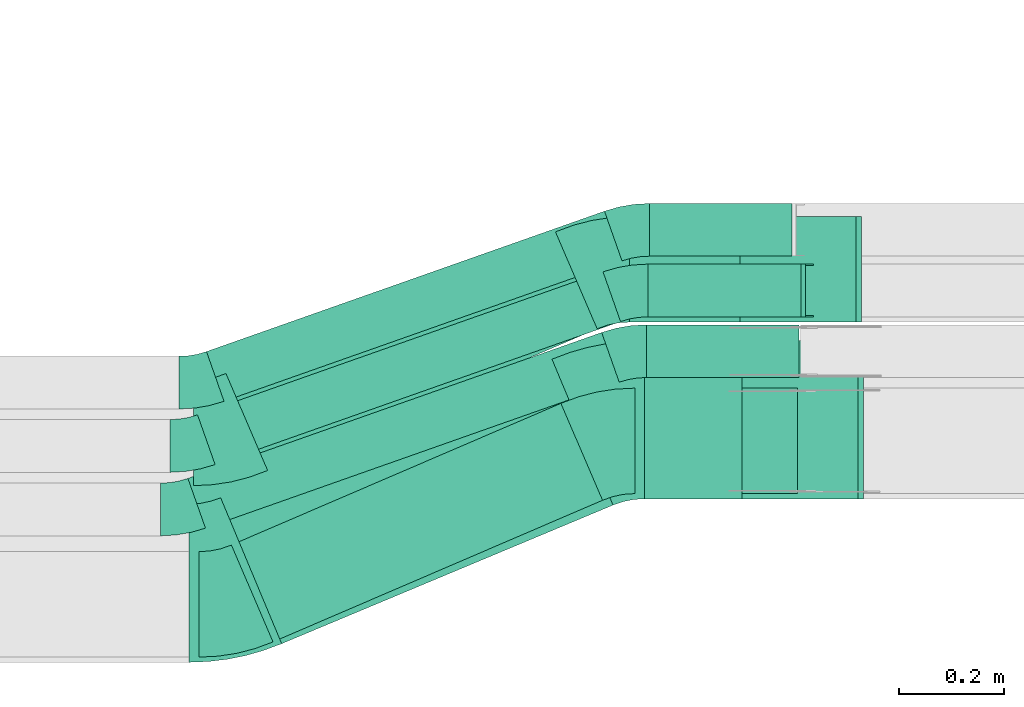
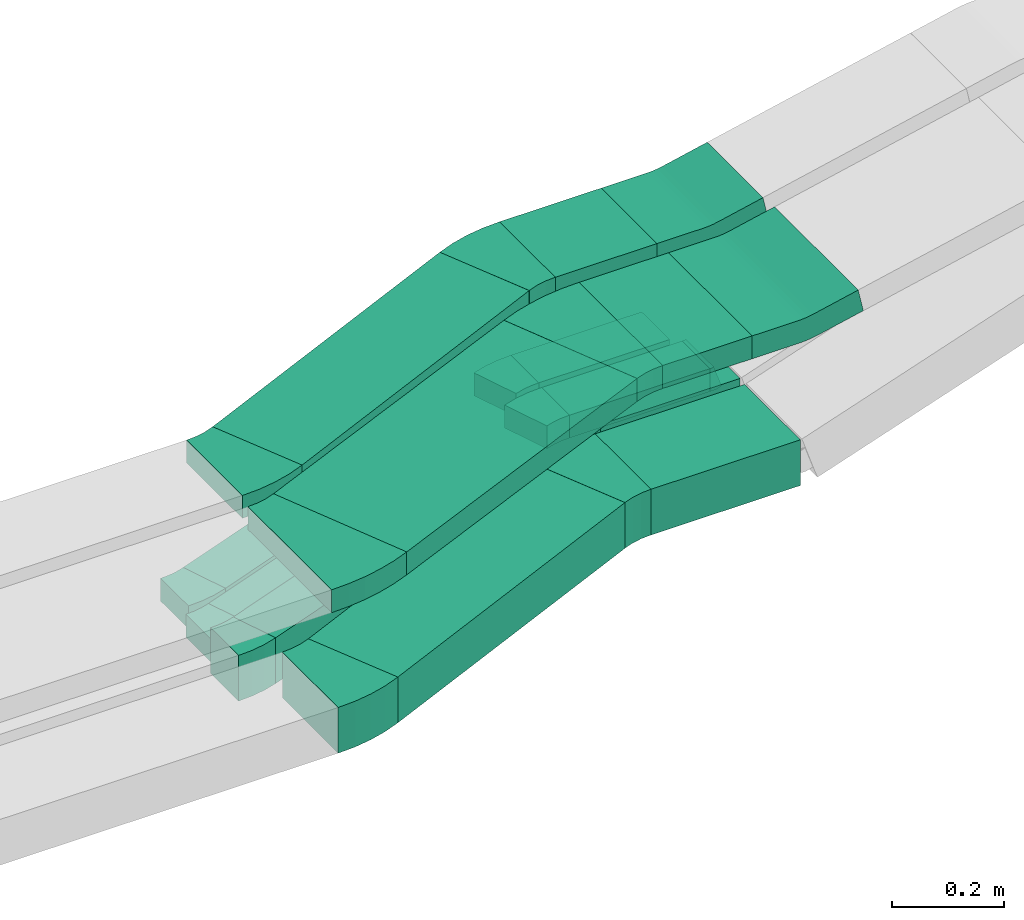
# One storey, part 9 of 31: 15 flow fittings, 12 flow segments.
"""IFC2X3 building model written with IfcOpenShell, lengths in millimetres."""

from ifc_helpers import new_model, entity, si_unit, converted_unit, derived_unit, direction, frame, frame_2d, origin, origin_2d_with_axis, place, context, subcontext, project, spatial, polyline, circle_curve, parameter, trimmed, segment, composite_curve, rectangle, outline, extrude, faceted_brep, source, transform, mapped, material, type_object, type_shapes, element, save


model = new_model("IFC2X3")

# Units and contexts
model_context = context("Model", 3, precision=0.01, world=origin(), true_north=direction((6.12303176911189e-17, 1.0)))
body_context = subcontext(model_context, "Body", "Model", "MODEL_VIEW")
ifc_project = project(units=[si_unit("LENGTHUNIT", "METRE", prefix="MILLI"), si_unit("AREAUNIT", "SQUARE_METRE"), si_unit("VOLUMEUNIT", "CUBIC_METRE"), converted_unit("PLANEANGLEUNIT", "DEGREE", entity("IfcRatioMeasure", 0.0174532925199433), si_unit("PLANEANGLEUNIT", "RADIAN"), dimensions=[0, 0, 0, 0, 0, 0, 0]), si_unit("MASSUNIT", "GRAM", prefix="KILO"), derived_unit("MASSDENSITYUNIT", [(si_unit("MASSUNIT", "GRAM", prefix="KILO"), 1), (si_unit("LENGTHUNIT", "METRE"), -3)]), derived_unit("MOMENTOFINERTIAUNIT", [(si_unit("LENGTHUNIT", "METRE"), 4)]), si_unit("TIMEUNIT", "SECOND"), si_unit("FREQUENCYUNIT", "HERTZ"), si_unit("THERMODYNAMICTEMPERATUREUNIT", "DEGREE_CELSIUS"), derived_unit("THERMALTRANSMITTANCEUNIT", [(si_unit("MASSUNIT", "GRAM", prefix="KILO"), 1), (si_unit("THERMODYNAMICTEMPERATUREUNIT", "KELVIN"), -1), (si_unit("TIMEUNIT", "SECOND"), -3)]), derived_unit("VOLUMETRICFLOWRATEUNIT", [(si_unit("LENGTHUNIT", "METRE"), 3), (si_unit("TIMEUNIT", "SECOND"), -1)]), derived_unit("MASSFLOWRATEUNIT", [(si_unit("MASSUNIT", "GRAM", prefix="KILO"), 1), (si_unit("TIMEUNIT", "SECOND"), -1)]), derived_unit("ROTATIONALFREQUENCYUNIT", [(si_unit("TIMEUNIT", "SECOND"), -1)]), si_unit("ELECTRICCURRENTUNIT", "AMPERE"), si_unit("ELECTRICVOLTAGEUNIT", "VOLT"), si_unit("POWERUNIT", "WATT"), si_unit("FORCEUNIT", "NEWTON", prefix="KILO"), si_unit("ILLUMINANCEUNIT", "LUX"), si_unit("LUMINOUSFLUXUNIT", "LUMEN"), si_unit("LUMINOUSINTENSITYUNIT", "CANDELA"), derived_unit("USERDEFINED", [(si_unit("MASSUNIT", "GRAM", prefix="KILO"), -1), (si_unit("LENGTHUNIT", "METRE"), -2), (si_unit("TIMEUNIT", "SECOND"), 3), (si_unit("LUMINOUSFLUXUNIT", "LUMEN"), 1)]), derived_unit("LINEARVELOCITYUNIT", [(si_unit("LENGTHUNIT", "METRE"), 1), (si_unit("TIMEUNIT", "SECOND"), -1)]), si_unit("PRESSUREUNIT", "PASCAL"), derived_unit("USERDEFINED", [(si_unit("LENGTHUNIT", "METRE"), -2), (si_unit("MASSUNIT", "GRAM", prefix="KILO"), 1), (si_unit("TIMEUNIT", "SECOND"), -2)]), derived_unit("LINEARFORCEUNIT", [(si_unit("MASSUNIT", "GRAM", prefix="KILO"), 1), (si_unit("LENGTHUNIT", "METRE"), 1), (si_unit("TIMEUNIT", "SECOND"), -2), (si_unit("LENGTHUNIT", "METRE"), -1)]), derived_unit("PLANARFORCEUNIT", [(si_unit("MASSUNIT", "GRAM", prefix="KILO"), 1), (si_unit("LENGTHUNIT", "METRE"), 1), (si_unit("TIMEUNIT", "SECOND"), -2), (si_unit("LENGTHUNIT", "METRE"), -2)])], contexts=[model_context])

# Site, building, storey
site_placement = place(None, frame((0.0, -0.00077364408347762, 0.0)))
site = spatial("IfcSite", under=ifc_project, at=site_placement, CompositionType="ELEMENT")
building_placement = place(site_placement, origin())
building = spatial("IfcBuilding", under=site, at=building_placement, CompositionType="ELEMENT")
storey_placement = place(building_placement, frame((0.0, 0.0, 15900.0)))
storey = spatial("IfcBuildingStorey", under=building, at=storey_placement, CompositionType="ELEMENT", Elevation=15900.0)

# Flow segments
cable_carrier_segment_type = type_object("IfcCableCarrierSegmentType", PredefinedType="CABLETRAYSEGMENT")
flow_segment_1_placement = place(storey_placement, frame((33944.9093442895, 8534.96624585791, 2500.0)))
element("IfcFlowSegment", 1, at=flow_segment_1_placement, inside=storey, type_object=cable_carrier_segment_type, context=body_context, shape_type="SweptSolid", body=[
    extrude(rectangle(XDim=308.884576377895, YDim=200.0, at=frame_2d((0.0, -5.47117906535277e-13), x_axis=(1.0, 0.0))), frame((154.442288188952, 100.0, 0.0), z_axis=(0.0, 0.0, 1.0), x_axis=(-1.0, 0.0, 0.0)), (0.0, 0.0, 1.0), 100.000000000001),
])
flow_segment_2_placement = place(storey_placement, frame((33934.6430443517, 8860.14880665487, 2820.0)))
element("IfcFlowSegment", 2, at=flow_segment_2_placement, inside=storey, type_object=cable_carrier_segment_type, context=body_context, shape_type="SweptSolid", body=[
    extrude(rectangle(XDim=210.233507475594, YDim=200.0, at=frame_2d((0.0, -5.47117906535277e-13), x_axis=(1.0, 0.0))), frame((105.116753737797, 100.0, 0.0), z_axis=(0.0, 0.0, 1.0), x_axis=(-1.0, 0.0, 0.0)), (0.0, 0.0, 1.0), 50.0000000000016),
])
flow_segment_3_placement = place(storey_placement, frame((33963.3976283758, 8525.14880665487, 2820.0)))
element("IfcFlowSegment", 3, at=flow_segment_3_placement, inside=storey, type_object=cable_carrier_segment_type, context=body_context, shape_type="SweptSolid", body=[
    extrude(rectangle(XDim=185.088523437471, YDim=300.000000000001, at=origin_2d_with_axis()), frame((92.5442617187313, 150.0, 0.0), z_axis=(0.0, 0.0, 1.0), x_axis=(-1.0, 0.0, 0.0)), (0.0, 0.0, 1.0), 50.0000000000016),
])
flow_segment_4_placement = place(storey_placement, frame((33179.8900724897, 8253.80326827144, 2500.0)))
element("IfcFlowSegment", 4, at=flow_segment_4_placement, inside=storey, type_object=cable_carrier_segment_type, context=body_context, shape_type="SweptSolid", body=[
    extrude(rectangle(XDim=680.16852764096, YDim=200.000000000003, at=origin_2d_with_axis()), frame((351.93496607342, 226.162977586453, 0.0), z_axis=(0.0, 0.0, 1.0), x_axis=(0.918736709350663, 0.394870686290481, 0.0)), (0.0, 0.0, 1.0), 99.9999999999989),
])
flow_segment_5_placement = place(storey_placement, frame((33169.623772552, 8578.98582906841, 2820.0)))
element("IfcFlowSegment", 5, at=flow_segment_5_placement, inside=storey, type_object=cable_carrier_segment_type, context=body_context, shape_type="SweptSolid", body=[
    extrude(rectangle(XDim=680.168527640881, YDim=200.000000000004, at=frame_2d((2.18847162614111e-12, -3.62376795237651e-13), x_axis=(1.0, 0.0))), frame((351.934966073381, 226.162977586447, 0.0), z_axis=(0.0, 0.0, 1.0), x_axis=(0.918736709350649, 0.394870686290513, 0.0)), (0.0, 0.0, 1.0), 50.0000000000016),
])
flow_segment_6_placement = place(storey_placement, frame((33159.5156243288, 8250.37654669365, 2820.0)))
element("IfcFlowSegment", 6, at=flow_segment_6_placement, inside=storey, type_object=cable_carrier_segment_type, context=body_context, shape_type="SweptSolid", body=[
    extrude(rectangle(XDim=681.07290656697, YDim=300.0, at=origin_2d_with_axis()), frame((372.043114296501, 269.772259961216, 0.0), z_axis=(0.0, 0.0, 1.0), x_axis=(0.922573514016603, 0.385821346266711, 0.0)), (0.0, 0.0, 1.0), 50.0000000000016),
])
flow_segment_7_placement = place(storey_placement, frame((33132.6784089911, 8710.06908501403, 2500.0)))
element("IfcFlowSegment", 7, at=flow_segment_7_placement, inside=storey, type_object=cable_carrier_segment_type, context=body_context, shape_type="SweptSolid", body=[
    extrude(rectangle(XDim=800.344538509501, YDim=99.9999999999954, at=frame_2d((-2.04636307898909e-12, 7.17648163117701e-13), x_axis=(1.0, 0.0))), frame((394.018301143796, 180.256395713795, 0.0), z_axis=(0.0, 0.0, 1.0), x_axis=(-0.943062738741533, -0.332614898640031, 0.0)), (0.0, 0.0, 1.0), 50.0000000000016),
])
flow_segment_8_placement = place(storey_placement, frame((33115.7081311074, 8590.06908501403, 2500.0)))
element("IfcFlowSegment", 8, at=flow_segment_8_placement, inside=storey, type_object=cable_carrier_segment_type, context=body_context, shape_type="SweptSolid", body=[
    extrude(rectangle(XDim=815.376937901308, YDim=99.9999999999954, at=frame_2d((1.90425453183707e-12, -1.22568621918617e-12), x_axis=(1.0, 0.0))), frame((401.106549013944, 182.756395713807, 0.0), z_axis=(0.0, 0.0, 1.0), x_axis=(0.943062738741534, 0.33261489864003, 0.0)), (0.0, 0.0, 1.0), 50.0000000000016),
])
flow_segment_9_placement = place(storey_placement, frame((33969.7565266701, 8870.14880665489, 2500.0)))
element("IfcFlowSegment", 9, at=flow_segment_9_placement, inside=storey, type_object=cable_carrier_segment_type, context=body_context, shape_type="SweptSolid", body=[
    extrude(rectangle(XDim=290.539792942886, YDim=100.000000000001, at=frame_2d((2.1600499167107e-12, -5.43565192856477e-13), x_axis=(1.0, 0.0))), frame((145.269896471449, 50.0, 0.0), z_axis=(0.0, 0.0, 1.0), x_axis=(-1.0, 0.0, 0.0)), (0.0, 0.0, 1.0), 50.0000000000016),
])
flow_segment_10_placement = place(storey_placement, frame((33097.4422629307, 8469.53317607114, 2500.0)))
element("IfcFlowSegment", 10, at=flow_segment_10_placement, inside=storey, type_object=cable_carrier_segment_type, context=body_context, shape_type="SweptSolid", body=[
    extrude(rectangle(XDim=832.020536746304, YDim=100.0, at=origin_2d_with_axis()), frame((408.954527968582, 185.524350185243, 0.0), z_axis=(0.0, 0.0, 1.0), x_axis=(0.943062738741517, 0.332614898640078, 0.0)), (0.0, 0.0, 1.0), 99.9999999999989),
])
flow_segment_11_placement = place(storey_placement, frame((33967.1866164027, 8755.14880665488, 2500.0)))
element("IfcFlowSegment", 11, at=flow_segment_11_placement, inside=storey, type_object=cable_carrier_segment_type, context=body_context, shape_type="SweptSolid", body=[
    extrude(rectangle(XDim=288.884576377908, YDim=100.000000000001, at=frame_2d((0.0, 5.43565192856477e-13), x_axis=(1.0, 0.0))), frame((144.442288188954, 50.0, 0.0), z_axis=(0.0, 0.0, 1.0), x_axis=(-1.0, 0.0, 0.0)), (0.0, 0.0, 1.0), 99.9999999999989),
])
flow_segment_12_placement = place(storey_placement, frame((33972.5503088135, 8985.14880665487, 2500.0)))
element("IfcFlowSegment", 12, at=flow_segment_12_placement, inside=storey, type_object=cable_carrier_segment_type, context=body_context, shape_type="SweptSolid", body=[
    extrude(rectangle(XDim=270.781498461428, YDim=99.9999999999989, at=frame_2d((0.0, -5.40012479177676e-13), x_axis=(1.0, 0.0))), frame((135.390749230714, 50.0, 0.0)), (0.0, 0.0, 1.0), 50.0000000000038),
])

# Flow fittings
ifc_material = material()
cable_carrier_fitting_type_1 = type_object("IfcCableCarrierFittingType", Name="470_DKC_S5_Variable Angle Elbow 0-45:-", PredefinedType="NOTDEFINED", material=ifc_material)
shared_shape_1 = source(origin(), body_context, "Body", "SweptSolid", [
    extrude(outline(composite_curve([segment(polyline([(-50.3385199636453, -110.256629002738), (-49.3385199636439, -110.256629002738)]), True, "CONTINUOUS"), segment(trimmed(circle_curve(frame_2d((-49.3385199636445, 239.743370997261), x_axis=(0.0, -1.0)), 350.0), [parameter(0.0)], [parameter(23.2579093419499)], True, "PARAMETER"), True, "CONTINUOUS"), segment(polyline([(88.8662202380144, -81.8144772754743), (89.7849569473644, -81.4196065891842)]), True, "CONTINUOUS"), segment(polyline([(89.7849569473644, -81.4196065891842), (10.810819689275, 102.327735280951)]), True, "CONTINUOUS"), segment(polyline([(10.810819689275, 102.327735280951), (9.89208297992356, 101.93286459466)]), True, "CONTINUOUS"), segment(trimmed(circle_curve(frame_2d((-49.3385199636445, 239.743370997261), x_axis=(0.0, -1.0)), 150.0), [parameter(0.0)], [parameter(23.2579093419499)], True, "PARAMETER"), False, "CONTINUOUS"), segment(polyline([(-49.3385199636439, 89.7433709972616), (-50.3385199636453, 89.7433709972616)]), True, "CONTINUOUS"), segment(polyline([(-50.3385199636453, 89.7433709972616), (-50.3385199636453, -110.256629002738)]), True, "CONTINUOUS")], self_intersect=False)), frame((-2.11078576522858, 10.2566290027302, -50.0)), (0.0, 0.0, 1.0), 100.0),
])
type_shapes(cable_carrier_fitting_type_1, [shared_shape_1])
flow_fitting_1_placement = place(storey_placement, frame((33171.1900385657, 8324.96624585791, 2550.0)))
element("IfcFlowFitting", 13, at=flow_fitting_1_placement, inside=storey, type_object=cable_carrier_fitting_type_1, material=ifc_material, Name="470_DKC_S5_Variable Angle Elbow 0-45:-", ObjectType="470_DKC_S5_Variable Angle Elbow 0-45:-", context=body_context, shape_type="MappedRepresentation", body=[
    mapped(shared_shape_1, transform((0.0, 0.0, 0.0), scale=1.0)),
])
flow_fitting_2_placement = place(storey_placement, frame((33892.4600385606, 8634.9662458579, 2550.0), z_axis=(0.0, 0.0, 1.0), x_axis=(-1.0, 0.0, 0.0)))
element("IfcFlowFitting", 14, at=flow_fitting_2_placement, inside=storey, type_object=cable_carrier_fitting_type_1, material=ifc_material, Name="470_DKC_S5_Variable Angle Elbow 0-45:-", ObjectType="470_DKC_S5_Variable Angle Elbow 0-45:-", context=body_context, shape_type="MappedRepresentation", body=[
    mapped(shared_shape_1, transform((0.0, 0.0, 0.0), scale=1.0)),
])
cable_carrier_fitting_type_2 = type_object("IfcCableCarrierFittingType", Name="470_DKC_S5_Variable Angle Elbow 0-45:-", PredefinedType="NOTDEFINED", material=ifc_material)
shared_shape_2 = source(origin(), body_context, "Body", "SweptSolid", [
    extrude(outline(composite_curve([segment(polyline([(-50.3385199636509, -110.256629002739), (-49.3385199636495, -110.256629002739)]), True, "CONTINUOUS"), segment(trimmed(circle_curve(frame_2d((-49.3385199636441, 239.743370997261), x_axis=(0.0, -1.0)), 350.0), [parameter(0.0)], [parameter(23.2579093419518)], True, "PARAMETER"), True, "CONTINUOUS"), segment(polyline([(88.8662202380198, -81.8144772754729), (89.7849569473705, -81.4196065891825)]), True, "CONTINUOUS"), segment(polyline([(89.7849569473705, -81.4196065891825), (10.8108196892767, 102.327735280951)]), True, "CONTINUOUS"), segment(polyline([(10.8108196892767, 102.327735280951), (9.8920829799261, 101.932864594661)]), True, "CONTINUOUS"), segment(trimmed(circle_curve(frame_2d((-49.3385199636441, 239.743370997261), x_axis=(0.0, -1.0)), 150.0), [parameter(0.0)], [parameter(23.2579093419518)], True, "PARAMETER"), False, "CONTINUOUS"), segment(polyline([(-49.3385199636461, 89.7433709972608), (-50.3385199636475, 89.7433709972608)]), True, "CONTINUOUS"), segment(polyline([(-50.3385199636475, 89.7433709972608), (-50.3385199636509, -110.256629002739)]), True, "CONTINUOUS")], self_intersect=False)), frame((-2.11078576523108, 10.2566290027318, -25.0)), (0.0, 0.0, 1.0), 50.0000000000006),
])
type_shapes(cable_carrier_fitting_type_2, [shared_shape_2])
flow_fitting_3_placement = place(storey_placement, frame((33160.9237386279, 8650.14880665487, 2845.0)))
element("IfcFlowFitting", 15, at=flow_fitting_3_placement, inside=storey, type_object=cable_carrier_fitting_type_2, material=ifc_material, Name="470_DKC_S5_Variable Angle Elbow 0-45:-", ObjectType="470_DKC_S5_Variable Angle Elbow 0-45:-", context=body_context, shape_type="MappedRepresentation", body=[
    mapped(shared_shape_2, transform((0.0, 0.0, 0.0), scale=1.0)),
])
flow_fitting_4_placement = place(storey_placement, frame((33882.1937386228, 8960.14880665486, 2845.0), z_axis=(0.0, 0.0, 1.0), x_axis=(-1.0, 0.0, 0.0)))
element("IfcFlowFitting", 16, at=flow_fitting_4_placement, inside=storey, type_object=cable_carrier_fitting_type_2, material=ifc_material, Name="470_DKC_S5_Variable Angle Elbow 0-45:-", ObjectType="470_DKC_S5_Variable Angle Elbow 0-45:-", context=body_context, shape_type="MappedRepresentation", body=[
    mapped(shared_shape_2, transform((0.0, 0.0, 0.0), scale=1.0)),
])
cable_carrier_fitting_type_3 = type_object("IfcCableCarrierFittingType", Name="470_DKC_S5_Variable Angle Elbow 0-45:-", PredefinedType="NOTDEFINED", material=ifc_material)
shared_shape_3 = source(origin(), body_context, "Body", "SweptSolid", [
    extrude(outline(composite_curve([segment(polyline([(-58.853845318505, -161.710428234076), (-57.8538453185034, -161.710428234076)]), True, "CONTINUOUS"), segment(trimmed(circle_curve(frame_2d((-57.8538453185117, 288.289571765924), x_axis=(0.0, -1.0)), 450.0), [parameter(0.0)], [parameter(22.6947399098988)], True, "PARAMETER"), True, "CONTINUOUS"), segment(polyline([(115.765760501503, -126.868509541549), (116.688334015519, -126.482688195282)]), True, "CONTINUOUS"), segment(polyline([(116.688334015519, -126.482688195282), (0.941930135510314, 150.2893660097)]), True, "CONTINUOUS"), segment(polyline([(0.941930135510339, 150.2893660097), (0.0193566214931236, 149.903544663433)]), True, "CONTINUOUS"), segment(trimmed(circle_curve(frame_2d((-57.8538453185117, 288.289571765924), x_axis=(0.0, -1.0)), 150.0), [parameter(0.0)], [parameter(22.6947399098988)], True, "PARAMETER"), False, "CONTINUOUS"), segment(polyline([(-57.8538453185084, 138.289571765924), (-58.85384531851, 138.289571765924)]), True, "CONTINUOUS"), segment(polyline([(-58.85384531851, 138.289571765924), (-58.853845318505, -161.710428234076)]), True, "CONTINUOUS")], self_intersect=False)), frame((-2.35004443454106, 11.7104282340665, -25.0)), (0.0, 0.0, 1.0), 49.9999999999992),
])
type_shapes(cable_carrier_fitting_type_3, [shared_shape_3])
flow_fitting_5_placement = place(storey_placement, frame((33160.9237386278, 8365.14880665487, 2845.0)))
element("IfcFlowFitting", 17, at=flow_fitting_5_placement, inside=storey, type_object=cable_carrier_fitting_type_3, material=ifc_material, Name="470_DKC_S5_Variable Angle Elbow 0-45:-", ObjectType="470_DKC_S5_Variable Angle Elbow 0-45:-", context=body_context, shape_type="MappedRepresentation", body=[
    mapped(shared_shape_3, transform((0.0, 0.0, 0.0), scale=1.0)),
])
flow_fitting_6_placement = place(storey_placement, frame((33902.1937386228, 8675.14880665486, 2845.0), z_axis=(0.0, 0.0, 1.0), x_axis=(-1.0, 0.0, 0.0)))
element("IfcFlowFitting", 18, at=flow_fitting_6_placement, inside=storey, type_object=cable_carrier_fitting_type_3, material=ifc_material, Name="470_DKC_S5_Variable Angle Elbow 0-45:-", ObjectType="470_DKC_S5_Variable Angle Elbow 0-45:-", context=body_context, shape_type="MappedRepresentation", body=[
    mapped(shared_shape_3, transform((0.0, 0.0, 0.0), scale=1.0)),
])
cable_carrier_fitting_type_4 = type_object("IfcCableCarrierFittingType", Name="470_DKC_S5_Variable Angle Elbow 0-45:-", PredefinedType="NOTDEFINED", material=ifc_material)
shared_shape_4 = source(origin(), body_context, "Body", "SweptSolid", [
    extrude(outline(composite_curve([segment(polyline([(-34.2472555486894, -55.7768798505066), (-33.2472555486881, -55.7768798505066)]), True, "CONTINUOUS"), segment(trimmed(circle_curve(frame_2d((-33.2472555486885, 194.223120149493), x_axis=(0.0, -1.0)), 250.0), [parameter(0.0)], [parameter(19.4275662628412)], True, "PARAMETER"), True, "CONTINUOUS"), segment(polyline([(49.9064691113192, -41.54256453589), (50.8495318500608, -41.20994963725)]), True, "CONTINUOUS"), segment(polyline([(50.8495318500607, -41.20994963725), (17.5880419860577, 53.0963242369033)]), True, "CONTINUOUS"), segment(polyline([(17.5880419860577, 53.0963242369033), (16.6449792473161, 52.7637093382632)]), True, "CONTINUOUS"), segment(trimmed(circle_curve(frame_2d((-33.2472555486885, 194.223120149493), x_axis=(0.0, -1.0)), 150.0), [parameter(0.0)], [parameter(19.4275662628412)], True, "PARAMETER"), False, "CONTINUOUS"), segment(polyline([(-33.2472555486881, 44.2231201494932), (-34.2472555486894, 44.2231201494932)]), True, "CONTINUOUS"), segment(polyline([(-34.2472555486894, 44.2231201494932), (-34.2472555486894, -55.7768798505066)]), True, "CONTINUOUS")], self_intersect=False)), frame((-0.988890511665827, 5.77687985049859, -25.0)), (0.0, 0.0, 1.0), 50.0000000000001),
])
type_shapes(cable_carrier_fitting_type_4, [shared_shape_4])
flow_fitting_7_placement = place(storey_placement, frame((33937.3141627531, 9035.14880665486, 2525.0), z_axis=(0.0, 0.0, 1.0), x_axis=(-1.0, 0.0, 0.0)))
element("IfcFlowFitting", 19, at=flow_fitting_7_placement, inside=storey, type_object=cable_carrier_fitting_type_4, material=ifc_material, Name="470_DKC_S5_Variable Angle Elbow 0-45:-", ObjectType="470_DKC_S5_Variable Angle Elbow 0-45:-", context=body_context, shape_type="MappedRepresentation", body=[
    mapped(shared_shape_4, transform((0.0, 0.0, 0.0), scale=1.0)),
])
for number, where, name in (
    (20, (33116.0792575167, 8745.50215480079, 2525.0), "470_DKC_S5_Variable Angle Elbow 0-45:-"),
    (21, (33099.108979633, 8625.50215480079, 2525.0), "470_DKC_S5_Variable Angle Elbow 0-45:-"),
):
    element("IfcFlowFitting", number, at=place(storey_placement, frame(where)), inside=storey, type_object=cable_carrier_fitting_type_4, material=ifc_material, Name=name, ObjectType="470_DKC_S5_Variable Angle Elbow 0-45:-", context=body_context, shape_type="MappedRepresentation", body=[
        mapped(shared_shape_4, transform((0.0, 0.0, 0.0), scale=1.0)),
    ])
flow_fitting_8_placement = place(storey_placement, frame((33934.5203806097, 8920.14880665488, 2525.0), z_axis=(0.0, 0.0, 1.0), x_axis=(-1.0, 0.0, 0.0)))
element("IfcFlowFitting", 22, at=flow_fitting_8_placement, inside=storey, type_object=cable_carrier_fitting_type_4, material=ifc_material, Name="470_DKC_S5_Variable Angle Elbow 0-45:-", ObjectType="470_DKC_S5_Variable Angle Elbow 0-45:-", context=body_context, shape_type="MappedRepresentation", body=[
    mapped(shared_shape_4, transform((0.0, 0.0, 0.0), scale=1.0)),
])
cable_carrier_fitting_type_5 = type_object("IfcCableCarrierFittingType", Name="470_DKC_S5_Variable Angle Elbow 0-45:-", PredefinedType="NOTDEFINED", material=ifc_material)
shared_shape_5 = source(origin(), body_context, "Body", "SweptSolid", [
    extrude(outline(composite_curve([segment(polyline([(-34.2472555486911, -55.7768798505077), (-33.2472555486897, -55.7768798505077)]), True, "CONTINUOUS"), segment(trimmed(circle_curve(frame_2d((-33.2472555486923, 194.223120149492), x_axis=(0.0, -1.0)), 250.0), [parameter(0.0)], [parameter(19.4275662628425)], True, "PARAMETER"), True, "CONTINUOUS"), segment(polyline([(49.9064691113228, -41.5425645358884), (50.8495318500642, -41.2099496372484)]), True, "CONTINUOUS"), segment(polyline([(50.8495318500642, -41.2099496372484), (17.5880419860585, 53.0963242369039)]), True, "CONTINUOUS"), segment(polyline([(17.5880419860585, 53.0963242369039), (16.6449792473168, 52.7637093382637)]), True, "CONTINUOUS"), segment(trimmed(circle_curve(frame_2d((-33.2472555486923, 194.223120149492), x_axis=(0.0, -1.0)), 150.0), [parameter(0.0)], [parameter(19.4275662628425)], True, "PARAMETER"), False, "CONTINUOUS"), segment(polyline([(-33.2472555486906, 44.2231201494922), (-34.2472555486919, 44.2231201494922)]), True, "CONTINUOUS"), segment(polyline([(-34.2472555486919, 44.2231201494922), (-34.2472555486911, -55.7768798505077)]), True, "CONTINUOUS")], self_intersect=False)), frame((-0.988890511666025, 5.77687985049935, -50.0)), (0.0, 0.0, 1.0), 100.0),
])
type_shapes(cable_carrier_fitting_type_5, [shared_shape_5])
flow_fitting_9_placement = place(storey_placement, frame((33080.8431114564, 8504.9662458579, 2550.0)))
element("IfcFlowFitting", 23, at=flow_fitting_9_placement, inside=storey, type_object=cable_carrier_fitting_type_5, material=ifc_material, Name="470_DKC_S5_Variable Angle Elbow 0-45:-", ObjectType="470_DKC_S5_Variable Angle Elbow 0-45:-", context=body_context, shape_type="MappedRepresentation", body=[
    mapped(shared_shape_5, transform((0.0, 0.0, 0.0), scale=1.0)),
])
flow_fitting_10_placement = place(storey_placement, frame((33931.9504703423, 8805.14880665487, 2550.0), z_axis=(0.0, 0.0, 1.0), x_axis=(-1.0, 0.0, 0.0)))
element("IfcFlowFitting", 24, at=flow_fitting_10_placement, inside=storey, type_object=cable_carrier_fitting_type_5, material=ifc_material, Name="470_DKC_S5_Variable Angle Elbow 0-45:-", ObjectType="470_DKC_S5_Variable Angle Elbow 0-45:-", context=body_context, shape_type="MappedRepresentation", body=[
    mapped(shared_shape_5, transform((0.0, 0.0, 0.0), scale=1.0)),
])
cable_carrier_fitting_type_6 = type_object("IfcCableCarrierFittingType", Name="470_DKC_S5_CD 90 external vertical angle:-", PredefinedType="NOTDEFINED", material=ifc_material)
shared_shape_6 = source(origin(), body_context, "Body", "SweptSolid", [
    extrude(outline(composite_curve([segment(polyline([(-112.891439064344, -31.9789171718148), (-16.9828263503482, -31.9789171718148)]), True, "CONTINUOUS"), segment(trimmed(circle_curve(frame_2d((-16.9828263503485, 158.021082828184), x_axis=(0.0, -1.0)), 189.999999999999), [parameter(0.0)], [parameter(12.2682836771792)], True, "PARAMETER"), True, "CONTINUOUS"), segment(polyline([(23.3901797752441, -27.6399534082391), (117.108560935656, -7.2603796787696)]), True, "CONTINUOUS"), segment(polyline([(117.108560935656, -7.26037967876959), (106.484085639448, 41.5977877518686)]), True, "CONTINUOUS"), segment(polyline([(106.484085639448, 41.5977877518686), (12.7657044790354, 21.2182140223991)]), True, "CONTINUOUS"), segment(trimmed(circle_curve(frame_2d((-16.9828263503485, 158.021082828184), x_axis=(0.0, -1.0)), 139.999999999999), [parameter(0.0)], [parameter(12.2682836771792)], True, "PARAMETER"), False, "CONTINUOUS"), segment(polyline([(-16.9828263503482, 18.0210828281855), (-112.891439064344, 18.0210828281855)]), True, "CONTINUOUS"), segment(polyline([(-112.891439064344, 18.0210828281855), (-112.891439064344, -31.9789171718148)]), True, "CONTINUOUS")], self_intersect=False)), frame((-0.750037503349171, 6.97891717180758, -150.0)), (0.0, 0.0, 1.0), 300.0),
])
type_shapes(cable_carrier_fitting_type_6, [shared_shape_6])
flow_fitting_11_placement = place(storey_placement, frame((34262.127628381, 8675.14880665488, 2845.0), z_axis=(0.0, -1.0, 0.0), x_axis=(1.0, 0.0, 0.0)))
element("IfcFlowFitting", 25, at=flow_fitting_11_placement, inside=storey, type_object=cable_carrier_fitting_type_6, material=ifc_material, Name="470_DKC_S5_CD 90 external vertical angle:-", ObjectType="470_DKC_S5_CD 90 external vertical angle:-", context=body_context, shape_type="MappedRepresentation", body=[
    mapped(shared_shape_6, transform((0.0, 0.0, 0.0), scale=1.0)),
])
cable_carrier_fitting_type_7 = type_object("IfcCableCarrierFittingType", Name="470_DKC_S5_CD 90 external vertical angle:-", PredefinedType="NOTDEFINED", material=ifc_material)
shared_shape_7 = source(origin(), body_context, "Body", "SweptSolid", [
    extrude(outline(composite_curve([segment(polyline([(-112.888323037853, -31.9939064861405), (-17.0140106209194, -31.9939064861405)]), True, "CONTINUOUS"), segment(trimmed(circle_curve(frame_2d((-17.0140106209197, 158.006093513858), x_axis=(0.0, -1.0)), 189.999999999999), [parameter(0.0)], [parameter(12.2917958116951)], True, "PARAMETER"), True, "CONTINUOUS"), segment(polyline([(23.4351807386065, -27.6383594556824), (117.111676962147, -7.22763098507425)]), True, "CONTINUOUS"), segment(polyline([(117.111676962147, -7.22763098507427), (106.467152920166, 41.6261724279633)]), True, "CONTINUOUS"), segment(polyline([(106.467152920166, 41.6261724279633), (12.7906566966258, 21.2154439573552)]), True, "CONTINUOUS"), segment(trimmed(circle_curve(frame_2d((-17.0140106209197, 158.006093513858), x_axis=(0.0, -1.0)), 139.999999999999), [parameter(0.0)], [parameter(12.2917958116951)], True, "PARAMETER"), False, "CONTINUOUS"), segment(polyline([(-17.0140106209194, 18.0060935138597), (-112.888323037853, 18.0060935138597)]), True, "CONTINUOUS"), segment(polyline([(-112.888323037853, 18.0060935138597), (-112.888323037853, -31.9939064861405)]), True, "CONTINUOUS")], self_intersect=False)), frame((-0.753100064619125, 6.99390648613325, -100.0)), (0.0, 0.0, 1.0), 200.0),
])
type_shapes(cable_carrier_fitting_type_7, [shared_shape_7])
flow_fitting_12_placement = place(storey_placement, frame((34258.5179749297, 8960.14880665488, 2845.0), z_axis=(0.0, -1.0, 0.0), x_axis=(1.0, 0.0, 0.0)))
element("IfcFlowFitting", 26, at=flow_fitting_12_placement, inside=storey, type_object=cable_carrier_fitting_type_7, material=ifc_material, Name="470_DKC_S5_CD 90 external vertical angle:-", ObjectType="470_DKC_S5_CD 90 external vertical angle:-", context=body_context, shape_type="MappedRepresentation", body=[
    mapped(shared_shape_7, transform((0.0, 0.0, 0.0), scale=1.0)),
])
cable_carrier_fitting_type_8 = type_object("IfcCableCarrierFittingType", PredefinedType="NOTDEFINED", material=ifc_material)
shared_shape_8 = source(origin(), body_context, "Body", "Brep", [
    faceted_brep([(-8.19020706225814, 25.0, 50.0), (-8.19020706225814, 25.0, -50.0), (-8.1902070622583, -25.0, -50.0), (-8.1902070622583, -25.0, -47.4600000101565), (-8.19020706225814, 22.46000001016, -47.4600000101565), (-8.19020706225814, 22.46000001016, 47.4600000101635), (-8.1902070622583, -25.0, 47.4600000101635), (-8.1902070622583, -25.0, 50.0), (-0.214015549035263, 26.30653320123, 50.0), (15.7383674774103, -21.080400396309, 50.0), (15.7383674774103, -21.080400396309, 47.4600000101635), (0.596365505466648, 23.8992769841041, 47.4600000101635), (0.596365505466639, 23.8992769841041, -47.4600000101565), (15.7383674774103, -21.080400396309, -47.4600000101565), (15.7383674774103, -21.080400396309, -50.0), (-0.21401554903526, 26.30653320123, -50.0), (-4.09510353112875, 25.0, 50.0), (-4.09510353112883, 25.0, -50.0), (4.09510353112973, -25.0, -50.0), (4.09510353112973, -25.0, -47.4600000101565), (-3.67904101403035, 22.46000001016, -47.4600000101565), (-3.67904101403035, 22.46000001016, 47.4600000101635), (4.09510353112973, -25.0, 47.4600000101635), (4.09510353112973, -25.0, 50.0)], [[[0, 1, 2, 3, 4, 5, 6, 7]], [[8, 9, 10, 11, 12, 13, 14, 15]], [[1, 0, 16, 17]], [[2, 1, 17, 15, 14, 18]], [[3, 2, 18, 19]], [[4, 3, 19, 13, 12, 20]], [[5, 4, 20, 21]], [[6, 5, 21, 11, 10, 22]], [[7, 6, 22, 23]], [[0, 7, 23, 9, 8, 16]], [[17, 16, 8, 15]], [[19, 18, 14, 13]], [[21, 20, 12, 11]], [[23, 22, 10, 9]]]),
])
type_shapes(cable_carrier_fitting_type_8, [shared_shape_8])
flow_fitting_13_placement = place(storey_placement, frame((34268.4865266752, 8920.1488066549, 2525.0), z_axis=(0.0, -1.0, 0.0), x_axis=(1.0, 0.0, 0.0)))
element("IfcFlowFitting", 27, at=flow_fitting_13_placement, inside=storey, type_object=cable_carrier_fitting_type_8, material=ifc_material, context=body_context, shape_type="MappedRepresentation", body=[
    mapped(shared_shape_8, transform((0.0, 0.0, 0.0), scale=1.0)),
])

save(model, "model.ifc")
